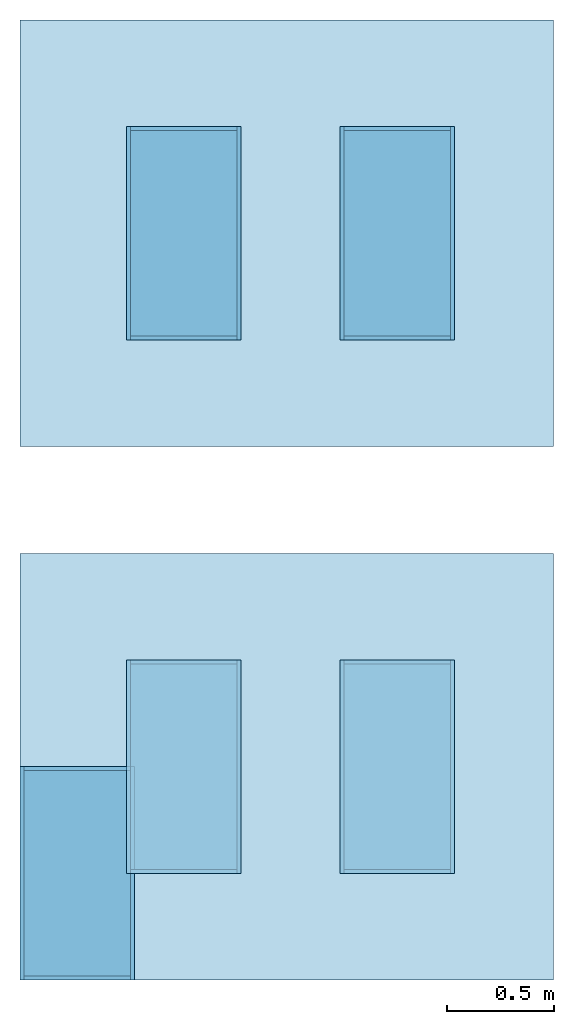
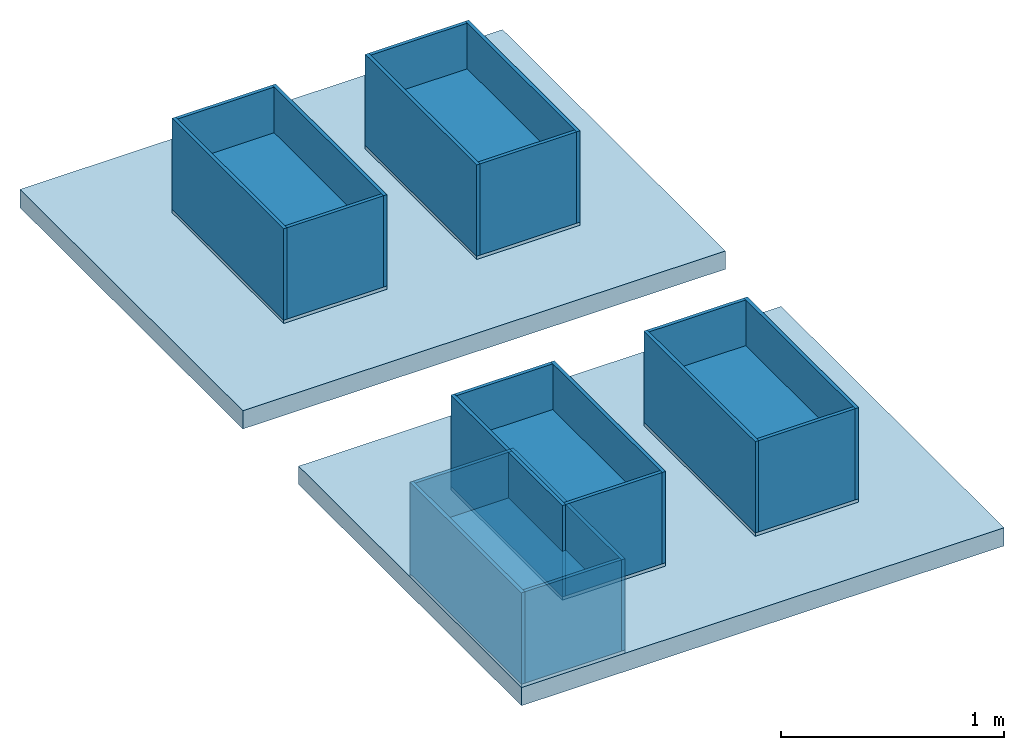
# One storey: 35 plates, 7 building element parts, 3 slabs, 8 elements without a shape of their own.
"""IFC4 building model written with IfcOpenShell, lengths in millimetres."""

from ifc_helpers import new_model, entity, si_unit, converted_unit, frame, origin_with_axes, origin_2d_with_axis, place, context, subcontext, project, spatial, rectangle, extrude, material, layer, layer_set, layer_usage, type_object, element, aggregate, save


model = new_model("IFC4")

# Units and contexts
model_context = context("Model", 3, precision=1e-05, world=origin_with_axes())
plan_context = context("Plan", 2, precision=1e-05, world=origin_2d_with_axis())
body_context = subcontext(model_context, "Body", "Model", "MODEL_VIEW")
ifc_project = project(units=[si_unit("VOLUMEUNIT", "CUBIC_METRE"), si_unit("LENGTHUNIT", "METRE", prefix="MILLI"), converted_unit("PLANEANGLEUNIT", "degree", entity("IfcReal", 0.0174532925199433), si_unit("PLANEANGLEUNIT", "RADIAN"), dimensions=[0, 0, 0, 0, 0, 0, 0]), si_unit("AREAUNIT", "SQUARE_METRE")], contexts=[model_context, plan_context])

# Site, building, storey
site_placement = place(None, origin_with_axes())
site = spatial("IfcSite", under=ifc_project, at=site_placement)
building_placement = place(site_placement, origin_with_axes())
building = spatial("IfcBuilding", under=site, at=building_placement, Name="Building")
storey_placement = place(building_placement, origin_with_axes())
storey = spatial("IfcBuildingStorey", under=building, at=storey_placement, Name="Storey")

# Plates
ifc_material_1 = material(Name="Timber", Category="TIMBER")
ifc_layer_1 = layer(ifc_material_1, 18.0)
ifc_layer_set_1 = layer_set([ifc_layer_1])
ifc_layer_usage_1 = layer_usage(ifc_layer_set_1, "AXIS3", "POSITIVE", 0.0)
plate_type = type_object("IfcPlateType", Name="t18", PredefinedType="SHEET", material=ifc_layer_set_1)
plate_1_placement = place(storey_placement, frame((268.0, 500.0, 0.0), z_axis=(0.0, 0.0, 1.0), x_axis=(1.0, 0.0, 0.0)))
element("IfcPlate", 1, at=plate_1_placement, inside=storey, type_object=plate_type, material=ifc_layer_usage_1, PredefinedType="SHEET", context=body_context, shape_type="SweptSolid", body=[
    extrude(rectangle(XDim=536.0, YDim=1000.0), None, (0.0, 0.0, 1.0), 18.0),
])
for number, where, z_axis, x_axis in (
    (2, (0.0, 500.0, 268.0), (1.0, 0.0, 0.0), (0.0, 0.0, 1.0)),
    (3, (518.0, 500.0, 268.0), (1.0, 0.0, 0.0), (0.0, 0.0, 1.0)),
):
    element("IfcPlate", number, at=place(storey_placement, frame(where, z_axis=z_axis, x_axis=x_axis)), inside=storey, type_object=plate_type, material=ifc_layer_usage_1, PredefinedType="SHEET", context=body_context, shape_type="SweptSolid", body=[
        extrude(rectangle(XDim=500.0, YDim=1000.0), None, (0.0, 0.0, 1.0), 18.0),
    ])
for number, where, z_axis, x_axis in (
    (4, (268.0, 0.0, 268.0), (0.0, 1.0, 0.0), (0.0, 0.0, 1.0)),
    (5, (268.0, 982.0, 268.0), (0.0, 1.0, 0.0), (0.0, 0.0, 1.0)),
):
    element("IfcPlate", number, at=place(storey_placement, frame(where, z_axis=z_axis, x_axis=x_axis)), inside=storey, type_object=plate_type, material=ifc_layer_usage_1, PredefinedType="SHEET", context=body_context, shape_type="SweptSolid", body=[
        extrude(rectangle(XDim=500.0, YDim=500.0), None, (0.0, 0.0, 1.0), 18.0),
    ])

# Slab
ifc_material_2 = material(Name="Concrete", Category="CONCRETE")
ifc_layer_2 = layer(ifc_material_2, 100.0)
ifc_layer_set_2 = layer_set([ifc_layer_2])
ifc_layer_usage_2 = layer_usage(ifc_layer_set_2, "AXIS3", "POSITIVE", 0.0)
slab_type = type_object("IfcSlabType", Name="Concrete100", PredefinedType="BASESLAB", material=ifc_layer_set_2)
slab_1_placement = place(storey_placement, frame((1250.0, 1000.0, -100.0), z_axis=(0.0, 0.0, 1.0), x_axis=(1.0, 0.0, 0.0)))
element("IfcSlab", 6, at=slab_1_placement, inside=storey, type_object=slab_type, material=ifc_layer_usage_2, Name="Slab 100", PredefinedType="BASESLAB", context=body_context, shape_type="SweptSolid", body=[
    extrude(rectangle(XDim=2500.0, YDim=2000.0), None, (0.0, 0.0, 1.0), 100.0),
])

# Assembly, plates
element_assembly_type_1 = type_object("IfcElementAssemblyType", Name="Sub-Assembly", PredefinedType="ACCESSORY_ASSEMBLY")
assembly_1_placement = place(storey_placement, frame((500.0, 500.0, 0.0)))
assembly_1 = element("IfcElementAssembly", 7, at=assembly_1_placement, inside=storey, type_object=element_assembly_type_1, Name="Sub-Assembly", PredefinedType="ACCESSORY_ASSEMBLY")
plate_2_placement = place(assembly_1_placement, frame((268.0, 500.0, 0.0), z_axis=(0.0, 0.0, 1.0), x_axis=(1.0, 0.0, 0.0)))
plate_2 = element("IfcPlate", 8, at=plate_2_placement, PredefinedType="SHEET", context=body_context, shape_type="SweptSolid", body=[
    extrude(rectangle(XDim=536.0, YDim=1000.0), None, (0.0, 0.0, 1.0), 18.0),
])
plate_3_placement = place(assembly_1_placement, frame((0.0, 500.0, 268.0), z_axis=(1.0, 0.0, 0.0), x_axis=(0.0, 0.0, 1.0)))
plate_3 = element("IfcPlate", 9, at=plate_3_placement, PredefinedType="SHEET", context=body_context, shape_type="SweptSolid", body=[
    extrude(rectangle(XDim=500.0, YDim=1000.0), None, (0.0, 0.0, 1.0), 18.0),
])
plate_4_placement = place(assembly_1_placement, frame((518.0, 500.0, 268.0), z_axis=(1.0, 0.0, 0.0), x_axis=(0.0, 0.0, 1.0)))
plate_4 = element("IfcPlate", 10, at=plate_4_placement, PredefinedType="SHEET", context=body_context, shape_type="SweptSolid", body=[
    extrude(rectangle(XDim=500.0, YDim=1000.0), None, (0.0, 0.0, 1.0), 18.0),
])
plate_5_placement = place(assembly_1_placement, frame((268.0, 0.0, 268.0), z_axis=(0.0, 1.0, 0.0), x_axis=(0.0, 0.0, 1.0)))
plate_5 = element("IfcPlate", 11, at=plate_5_placement, PredefinedType="SHEET", context=body_context, shape_type="SweptSolid", body=[
    extrude(rectangle(XDim=500.0, YDim=500.0), None, (0.0, 0.0, 1.0), 18.0),
])
plate_6_placement = place(assembly_1_placement, frame((268.0, 982.0, 268.0), z_axis=(0.0, 1.0, 0.0), x_axis=(0.0, 0.0, 1.0)))
plate_6 = element("IfcPlate", 12, at=plate_6_placement, PredefinedType="SHEET", context=body_context, shape_type="SweptSolid", body=[
    extrude(rectangle(XDim=500.0, YDim=500.0), None, (0.0, 0.0, 1.0), 18.0),
])

assembly_2_placement = place(storey_placement, frame((1500.0, 500.0, 0.0)))
assembly_2 = element("IfcElementAssembly", 13, at=assembly_2_placement, inside=storey, type_object=element_assembly_type_1, Name="Sub-Assembly", PredefinedType="ACCESSORY_ASSEMBLY")
plate_7_placement = place(assembly_2_placement, frame((268.0, 500.0, 0.0), z_axis=(0.0, 0.0, 1.0), x_axis=(1.0, 0.0, 0.0)))
plate_7 = element("IfcPlate", 14, at=plate_7_placement, PredefinedType="SHEET", context=body_context, shape_type="SweptSolid", body=[
    extrude(rectangle(XDim=536.0, YDim=1000.0), None, (0.0, 0.0, 1.0), 18.0),
])
plate_8_placement = place(assembly_2_placement, frame((0.0, 500.0, 268.0), z_axis=(1.0, 0.0, 0.0), x_axis=(0.0, 0.0, 1.0)))
plate_8 = element("IfcPlate", 15, at=plate_8_placement, PredefinedType="SHEET", context=body_context, shape_type="SweptSolid", body=[
    extrude(rectangle(XDim=500.0, YDim=1000.0), None, (0.0, 0.0, 1.0), 18.0),
])
plate_9_placement = place(assembly_2_placement, frame((518.0, 500.0, 268.0), z_axis=(1.0, 0.0, 0.0), x_axis=(0.0, 0.0, 1.0)))
plate_9 = element("IfcPlate", 16, at=plate_9_placement, PredefinedType="SHEET", context=body_context, shape_type="SweptSolid", body=[
    extrude(rectangle(XDim=500.0, YDim=1000.0), None, (0.0, 0.0, 1.0), 18.0),
])
plate_10_placement = place(assembly_2_placement, frame((268.0, 0.0, 268.0), z_axis=(0.0, 1.0, 0.0), x_axis=(0.0, 0.0, 1.0)))
plate_10 = element("IfcPlate", 17, at=plate_10_placement, PredefinedType="SHEET", context=body_context, shape_type="SweptSolid", body=[
    extrude(rectangle(XDim=500.0, YDim=500.0), None, (0.0, 0.0, 1.0), 18.0),
])
plate_11_placement = place(assembly_2_placement, frame((268.0, 982.0, 268.0), z_axis=(0.0, 1.0, 0.0), x_axis=(0.0, 0.0, 1.0)))
plate_11 = element("IfcPlate", 18, at=plate_11_placement, PredefinedType="SHEET", context=body_context, shape_type="SweptSolid", body=[
    extrude(rectangle(XDim=500.0, YDim=500.0), None, (0.0, 0.0, 1.0), 18.0),
])

# Assembly, slab
element_assembly_type_2 = type_object("IfcElementAssemblyType", Name="Assembly", PredefinedType="ACCESSORY_ASSEMBLY")
assembly_3_placement = place(storey_placement, origin_with_axes())
assembly_3 = element("IfcElementAssembly", 19, at=assembly_3_placement, inside=storey, type_object=element_assembly_type_2, Name="Assembly", PredefinedType="ACCESSORY_ASSEMBLY")
slab_2_placement = place(assembly_3_placement, frame((1250.0, 1000.0, -100.0), z_axis=(0.0, 0.0, 1.0), x_axis=(1.0, 0.0, 0.0)))
slab_2 = element("IfcSlab", 20, at=slab_2_placement, Name="Slab 100", PredefinedType="BASESLAB", context=body_context, shape_type="SweptSolid", body=[
    extrude(rectangle(XDim=2500.0, YDim=2000.0), None, (0.0, 0.0, 1.0), 100.0),
])

assembly_4_placement = place(storey_placement, frame((0.0, 2500.0, 0.0)))
assembly_4 = element("IfcElementAssembly", 21, at=assembly_4_placement, inside=storey, type_object=element_assembly_type_2, Name="Assembly", PredefinedType="ACCESSORY_ASSEMBLY")
slab_3_placement = place(assembly_4_placement, frame((1250.0, 1000.0, -100.0), z_axis=(0.0, 0.0, 1.0), x_axis=(1.0, 0.0, 0.0)))
slab_3 = element("IfcSlab", 22, at=slab_3_placement, Name="Slab 100", PredefinedType="BASESLAB", context=body_context, shape_type="SweptSolid", body=[
    extrude(rectangle(XDim=2500.0, YDim=2000.0), None, (0.0, 0.0, 1.0), 100.0),
])

# Assembly, plates
assembly_5_placement = place(assembly_3_placement, frame((500.0, 500.0, 0.0)))
assembly_5 = element("IfcElementAssembly", 23, at=assembly_5_placement, Name="Sub-Assembly", PredefinedType="ACCESSORY_ASSEMBLY")
plate_12_placement = place(assembly_5_placement, frame((268.0, 500.0, 0.0), z_axis=(0.0, 0.0, 1.0), x_axis=(1.0, 0.0, 0.0)))
plate_12 = element("IfcPlate", 24, at=plate_12_placement, PredefinedType="SHEET", context=body_context, shape_type="SweptSolid", body=[
    extrude(rectangle(XDim=536.0, YDim=1000.0), None, (0.0, 0.0, 1.0), 18.0),
])
plate_13_placement = place(assembly_5_placement, frame((0.0, 500.0, 268.0), z_axis=(1.0, 0.0, 0.0), x_axis=(0.0, 0.0, 1.0)))
plate_13 = element("IfcPlate", 25, at=plate_13_placement, PredefinedType="SHEET", context=body_context, shape_type="SweptSolid", body=[
    extrude(rectangle(XDim=500.0, YDim=1000.0), None, (0.0, 0.0, 1.0), 18.0),
])
plate_14_placement = place(assembly_5_placement, frame((518.0, 500.0, 268.0), z_axis=(1.0, 0.0, 0.0), x_axis=(0.0, 0.0, 1.0)))
plate_14 = element("IfcPlate", 26, at=plate_14_placement, PredefinedType="SHEET", context=body_context, shape_type="SweptSolid", body=[
    extrude(rectangle(XDim=500.0, YDim=1000.0), None, (0.0, 0.0, 1.0), 18.0),
])
plate_15_placement = place(assembly_5_placement, frame((268.0, 0.0, 268.0), z_axis=(0.0, 1.0, 0.0), x_axis=(0.0, 0.0, 1.0)))
plate_15 = element("IfcPlate", 27, at=plate_15_placement, PredefinedType="SHEET", context=body_context, shape_type="SweptSolid", body=[
    extrude(rectangle(XDim=500.0, YDim=500.0), None, (0.0, 0.0, 1.0), 18.0),
])
plate_16_placement = place(assembly_5_placement, frame((268.0, 982.0, 268.0), z_axis=(0.0, 1.0, 0.0), x_axis=(0.0, 0.0, 1.0)))
plate_16 = element("IfcPlate", 28, at=plate_16_placement, PredefinedType="SHEET", context=body_context, shape_type="SweptSolid", body=[
    extrude(rectangle(XDim=500.0, YDim=500.0), None, (0.0, 0.0, 1.0), 18.0),
])

# Assembly
assembly_6_placement = place(assembly_3_placement, frame((1500.0, 500.0, 0.0)))
assembly_6 = element("IfcElementAssembly", 29, at=assembly_6_placement, Name="Sub-Assembly", PredefinedType="ACCESSORY_ASSEMBLY")

aggregate(assembly_3, [assembly_5, assembly_6, slab_2])

# Plate
plate_17_placement = place(assembly_6_placement, frame((268.0, 500.0, 0.0), z_axis=(0.0, 0.0, 1.0), x_axis=(1.0, 0.0, 0.0)))
plate_17 = element("IfcPlate", 30, at=plate_17_placement, PredefinedType="SHEET", context=body_context, shape_type="SweptSolid", body=[
    extrude(rectangle(XDim=536.0, YDim=1000.0), None, (0.0, 0.0, 1.0), 18.0),
])

plate_18_placement = place(assembly_6_placement, frame((0.0, 500.0, 268.0), z_axis=(1.0, 0.0, 0.0), x_axis=(0.0, 0.0, 1.0)))
plate_18 = element("IfcPlate", 31, at=plate_18_placement, PredefinedType="SHEET", context=body_context, shape_type="SweptSolid", body=[
    extrude(rectangle(XDim=500.0, YDim=1000.0), None, (0.0, 0.0, 1.0), 18.0),
])

plate_19_placement = place(assembly_6_placement, frame((518.0, 500.0, 268.0), z_axis=(1.0, 0.0, 0.0), x_axis=(0.0, 0.0, 1.0)))
plate_19 = element("IfcPlate", 32, at=plate_19_placement, PredefinedType="SHEET", context=body_context, shape_type="SweptSolid", body=[
    extrude(rectangle(XDim=500.0, YDim=1000.0), None, (0.0, 0.0, 1.0), 18.0),
])

plate_20_placement = place(assembly_6_placement, frame((268.0, 0.0, 268.0), z_axis=(0.0, 1.0, 0.0), x_axis=(0.0, 0.0, 1.0)))
plate_20 = element("IfcPlate", 33, at=plate_20_placement, PredefinedType="SHEET", context=body_context, shape_type="SweptSolid", body=[
    extrude(rectangle(XDim=500.0, YDim=500.0), None, (0.0, 0.0, 1.0), 18.0),
])

plate_21_placement = place(assembly_6_placement, frame((268.0, 982.0, 268.0), z_axis=(0.0, 1.0, 0.0), x_axis=(0.0, 0.0, 1.0)))
plate_21 = element("IfcPlate", 34, at=plate_21_placement, PredefinedType="SHEET", context=body_context, shape_type="SweptSolid", body=[
    extrude(rectangle(XDim=500.0, YDim=500.0), None, (0.0, 0.0, 1.0), 18.0),
])

# Assembly, plates
assembly_7_placement = place(assembly_4_placement, frame((500.0, 500.0, 0.0)))
assembly_7 = element("IfcElementAssembly", 35, at=assembly_7_placement, Name="Sub-Assembly", PredefinedType="ACCESSORY_ASSEMBLY")
plate_22_placement = place(assembly_7_placement, frame((268.0, 500.0, 0.0), z_axis=(0.0, 0.0, 1.0), x_axis=(1.0, 0.0, 0.0)))
plate_22 = element("IfcPlate", 36, at=plate_22_placement, PredefinedType="SHEET", context=body_context, shape_type="SweptSolid", body=[
    extrude(rectangle(XDim=536.0, YDim=1000.0), None, (0.0, 0.0, 1.0), 18.0),
])
plate_23_placement = place(assembly_7_placement, frame((0.0, 500.0, 268.0), z_axis=(1.0, 0.0, 0.0), x_axis=(0.0, 0.0, 1.0)))
plate_23 = element("IfcPlate", 37, at=plate_23_placement, PredefinedType="SHEET", context=body_context, shape_type="SweptSolid", body=[
    extrude(rectangle(XDim=500.0, YDim=1000.0), None, (0.0, 0.0, 1.0), 18.0),
])
plate_24_placement = place(assembly_7_placement, frame((518.0, 500.0, 268.0), z_axis=(1.0, 0.0, 0.0), x_axis=(0.0, 0.0, 1.0)))
plate_24 = element("IfcPlate", 38, at=plate_24_placement, PredefinedType="SHEET", context=body_context, shape_type="SweptSolid", body=[
    extrude(rectangle(XDim=500.0, YDim=1000.0), None, (0.0, 0.0, 1.0), 18.0),
])
plate_25_placement = place(assembly_7_placement, frame((268.0, 0.0, 268.0), z_axis=(0.0, 1.0, 0.0), x_axis=(0.0, 0.0, 1.0)))
plate_25 = element("IfcPlate", 39, at=plate_25_placement, PredefinedType="SHEET", context=body_context, shape_type="SweptSolid", body=[
    extrude(rectangle(XDim=500.0, YDim=500.0), None, (0.0, 0.0, 1.0), 18.0),
])
plate_26_placement = place(assembly_7_placement, frame((268.0, 982.0, 268.0), z_axis=(0.0, 1.0, 0.0), x_axis=(0.0, 0.0, 1.0)))
plate_26 = element("IfcPlate", 40, at=plate_26_placement, PredefinedType="SHEET", context=body_context, shape_type="SweptSolid", body=[
    extrude(rectangle(XDim=500.0, YDim=500.0), None, (0.0, 0.0, 1.0), 18.0),
])

# Assembly
assembly_8_placement = place(assembly_4_placement, frame((1500.0, 500.0, 0.0)))
assembly_8 = element("IfcElementAssembly", 41, at=assembly_8_placement, Name="Sub-Assembly", PredefinedType="ACCESSORY_ASSEMBLY")

aggregate(assembly_4, [assembly_7, assembly_8, slab_3])

# Plate
plate_27_placement = place(assembly_8_placement, frame((268.0, 500.0, 0.0), z_axis=(0.0, 0.0, 1.0), x_axis=(1.0, 0.0, 0.0)))
plate_27 = element("IfcPlate", 42, at=plate_27_placement, PredefinedType="SHEET", context=body_context, shape_type="SweptSolid", body=[
    extrude(rectangle(XDim=536.0, YDim=1000.0), None, (0.0, 0.0, 1.0), 18.0),
])

plate_28_placement = place(assembly_8_placement, frame((0.0, 500.0, 268.0), z_axis=(1.0, 0.0, 0.0), x_axis=(0.0, 0.0, 1.0)))
plate_28 = element("IfcPlate", 43, at=plate_28_placement, PredefinedType="SHEET", context=body_context, shape_type="SweptSolid", body=[
    extrude(rectangle(XDim=500.0, YDim=1000.0), None, (0.0, 0.0, 1.0), 18.0),
])

plate_29_placement = place(assembly_8_placement, frame((518.0, 500.0, 268.0), z_axis=(1.0, 0.0, 0.0), x_axis=(0.0, 0.0, 1.0)))
plate_29 = element("IfcPlate", 44, at=plate_29_placement, PredefinedType="SHEET", context=body_context, shape_type="SweptSolid", body=[
    extrude(rectangle(XDim=500.0, YDim=1000.0), None, (0.0, 0.0, 1.0), 18.0),
])

plate_30_placement = place(assembly_8_placement, frame((268.0, 0.0, 268.0), z_axis=(0.0, 1.0, 0.0), x_axis=(0.0, 0.0, 1.0)))
plate_30 = element("IfcPlate", 45, at=plate_30_placement, PredefinedType="SHEET", context=body_context, shape_type="SweptSolid", body=[
    extrude(rectangle(XDim=500.0, YDim=500.0), None, (0.0, 0.0, 1.0), 18.0),
])

plate_31_placement = place(assembly_8_placement, frame((268.0, 982.0, 268.0), z_axis=(0.0, 1.0, 0.0), x_axis=(0.0, 0.0, 1.0)))
plate_31 = element("IfcPlate", 46, at=plate_31_placement, PredefinedType="SHEET", context=body_context, shape_type="SweptSolid", body=[
    extrude(rectangle(XDim=500.0, YDim=500.0), None, (0.0, 0.0, 1.0), 18.0),
])

# Building element part
ifc_material_3 = material(Name="Rockwool")
ifc_layer_3 = layer(ifc_material_3, 250.0)
ifc_layer_set_3 = layer_set([ifc_layer_3])
ifc_layer_usage_3 = layer_usage(ifc_layer_set_3, "AXIS2", "POSITIVE", 0.0)
building_element_part_type = type_object("IfcBuildingElementPartType", Name="Insulation250", PredefinedType="INSULATION", material=ifc_layer_set_3)
building_element_part_1_placement = place(storey_placement, frame((268.0, 500.0, 18.0), z_axis=(0.0, 0.0, 1.0), x_axis=(1.0, 0.0, 0.0)))
element("IfcBuildingElementPart", 47, at=building_element_part_1_placement, inside=storey, type_object=building_element_part_type, material=ifc_layer_usage_3, Name="Insulation 250", PredefinedType="INSULATION", context=body_context, shape_type="SweptSolid", body=[
    extrude(rectangle(XDim=500.0, YDim=964.0), None, (0.0, 0.0, 1.0), 250.0),
])

building_element_part_2_placement = place(assembly_1_placement, frame((268.0, 500.0, 18.0), z_axis=(0.0, 0.0, 1.0), x_axis=(1.0, 0.0, 0.0)))
building_element_part_2 = element("IfcBuildingElementPart", 48, at=building_element_part_2_placement, Name="Insulation 250", PredefinedType="INSULATION", context=body_context, shape_type="SweptSolid", body=[
    extrude(rectangle(XDim=500.0, YDim=964.0), None, (0.0, 0.0, 1.0), 250.0),
])

aggregate(assembly_1, [plate_2, plate_3, plate_4, plate_5, plate_6, building_element_part_2])

building_element_part_3_placement = place(assembly_2_placement, frame((268.0, 500.0, 18.0), z_axis=(0.0, 0.0, 1.0), x_axis=(1.0, 0.0, 0.0)))
building_element_part_3 = element("IfcBuildingElementPart", 49, at=building_element_part_3_placement, Name="Insulation 250", PredefinedType="INSULATION", context=body_context, shape_type="SweptSolid", body=[
    extrude(rectangle(XDim=500.0, YDim=964.0), None, (0.0, 0.0, 1.0), 250.0),
])

aggregate(assembly_2, [plate_7, plate_8, plate_9, plate_10, plate_11, building_element_part_3])

building_element_part_4_placement = place(assembly_5_placement, frame((268.0, 500.0, 18.0), z_axis=(0.0, 0.0, 1.0), x_axis=(1.0, 0.0, 0.0)))
building_element_part_4 = element("IfcBuildingElementPart", 50, at=building_element_part_4_placement, Name="Insulation 250", PredefinedType="INSULATION", context=body_context, shape_type="SweptSolid", body=[
    extrude(rectangle(XDim=500.0, YDim=964.0), None, (0.0, 0.0, 1.0), 250.0),
])

aggregate(assembly_5, [plate_12, plate_13, plate_14, plate_15, plate_16, building_element_part_4])

building_element_part_5_placement = place(assembly_6_placement, frame((268.0, 500.0, 18.0), z_axis=(0.0, 0.0, 1.0), x_axis=(1.0, 0.0, 0.0)))
building_element_part_5 = element("IfcBuildingElementPart", 51, at=building_element_part_5_placement, Name="Insulation 250", PredefinedType="INSULATION", context=body_context, shape_type="SweptSolid", body=[
    extrude(rectangle(XDim=500.0, YDim=964.0), None, (0.0, 0.0, 1.0), 250.0),
])

aggregate(assembly_6, [plate_17, plate_18, plate_19, plate_20, plate_21, building_element_part_5])

building_element_part_6_placement = place(assembly_7_placement, frame((268.0, 500.0, 18.0), z_axis=(0.0, 0.0, 1.0), x_axis=(1.0, 0.0, 0.0)))
building_element_part_6 = element("IfcBuildingElementPart", 52, at=building_element_part_6_placement, Name="Insulation 250", PredefinedType="INSULATION", context=body_context, shape_type="SweptSolid", body=[
    extrude(rectangle(XDim=500.0, YDim=964.0), None, (0.0, 0.0, 1.0), 250.0),
])

aggregate(assembly_7, [plate_22, plate_23, plate_24, plate_25, plate_26, building_element_part_6])

building_element_part_7_placement = place(assembly_8_placement, frame((268.0, 500.0, 18.0), z_axis=(0.0, 0.0, 1.0), x_axis=(1.0, 0.0, 0.0)))
building_element_part_7 = element("IfcBuildingElementPart", 53, at=building_element_part_7_placement, Name="Insulation 250", PredefinedType="INSULATION", context=body_context, shape_type="SweptSolid", body=[
    extrude(rectangle(XDim=500.0, YDim=964.0), None, (0.0, 0.0, 1.0), 250.0),
])

aggregate(assembly_8, [plate_27, plate_28, plate_29, plate_30, plate_31, building_element_part_7])

save(model, "model.ifc")
